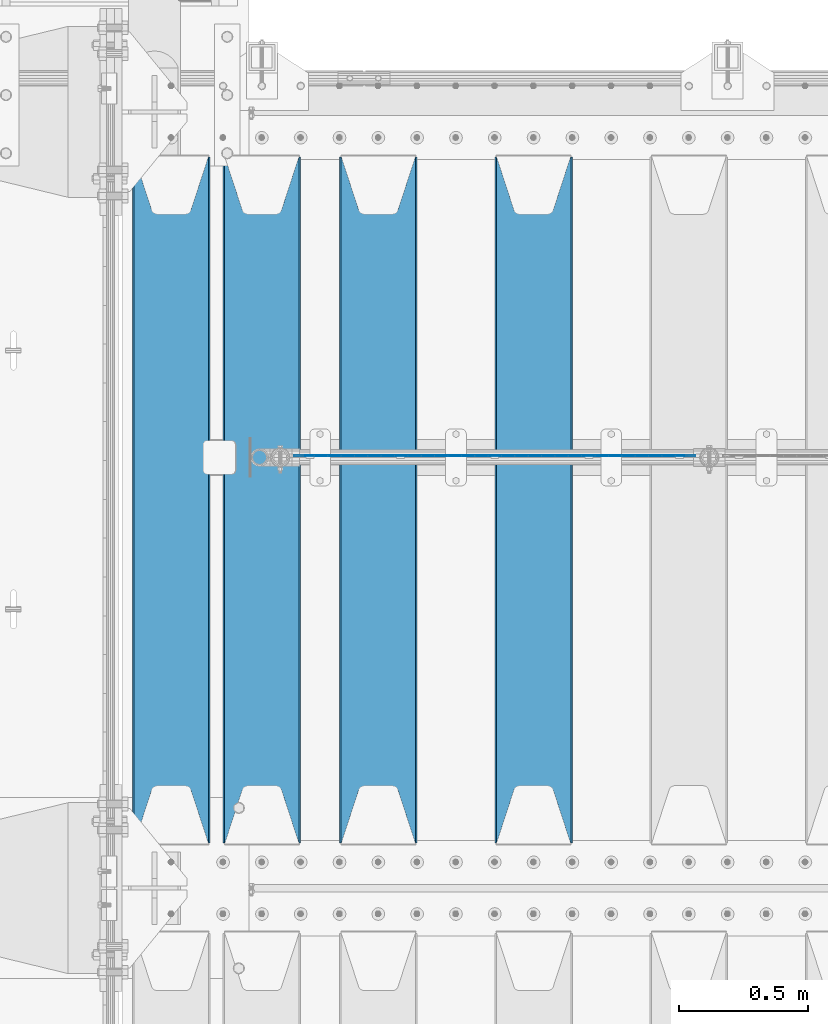
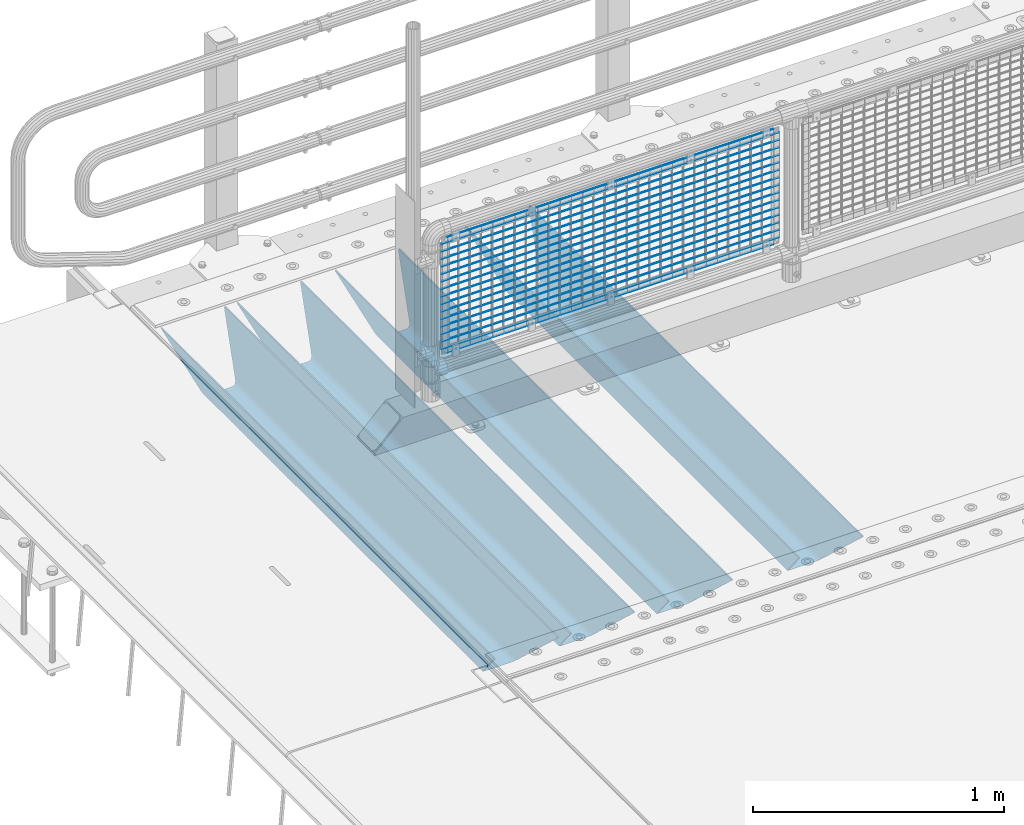
# One storey, part 88 of 193: 21 beams.
"""IFC2X3 building model written with IfcOpenShell, lengths in millimetres."""

from ifc_helpers import new_model, si_unit, frame, origin_with_axes, place, context, subcontext, project, spatial, faceted_brep, material, type_object, element, save


model = new_model("IFC2X3")

# Units and contexts
model_context = context("Model", 3, precision=1e-05, world=origin_with_axes())
body_context = subcontext(model_context, "Body", "Model", "MODEL_VIEW")
ifc_project = project(units=[si_unit("LENGTHUNIT", "METRE", prefix="MILLI"), si_unit("AREAUNIT", "SQUARE_METRE"), si_unit("VOLUMEUNIT", "CUBIC_METRE"), si_unit("MASSUNIT", "GRAM", prefix="KILO"), si_unit("TIMEUNIT", "SECOND"), si_unit("PLANEANGLEUNIT", "RADIAN"), si_unit("SOLIDANGLEUNIT", "STERADIAN"), si_unit("THERMODYNAMICTEMPERATUREUNIT", "DEGREE_CELSIUS"), si_unit("LUMINOUSINTENSITYUNIT", "LUMEN")], contexts=[model_context])

# Site, building, storey
site_placement = place(None, origin_with_axes())
site = spatial("IfcSite", under=ifc_project, at=site_placement, CompositionType="ELEMENT")
building_placement = place(site_placement, origin_with_axes())
building = spatial("IfcBuilding", under=site, at=building_placement, Name="Standard", CompositionType="ELEMENT")
storey_placement = place(building_placement, origin_with_axes())
storey = spatial("IfcBuildingStorey", under=building, at=storey_placement, Name="Undefined", CompositionType="ELEMENT", Elevation=0.0)

# Beams
ifc_material_1 = material(Name="STEEL/S355N")
beam_type_1 = type_object("IfcBeamType", PredefinedType="NOTDEFINED")
beam_1_placement = place(storey_placement, frame((-40850.0, 27175.0, -115.0), z_axis=(0.0, 0.0, 1.0), x_axis=(0.0, 1.0, 0.0)))
element("IfcBeam", 1, at=beam_1_placement, inside=storey, type_object=beam_type_1, material=ifc_material_1, context=body_context, shape_type="Brep", body=[
    faceted_brep([(0.0, 150.0, 115.0), (0.0, 143.689999999999, 115.0), (2650.00000000297, 143.689999999999, 115.0), (2650.00000000297, 150.0, 115.0), (2650.00000000297, 142.059565218398, 110.000000003094), (2650.00000000297, 148.3695652184, 110.000000003094), (2441.90079219209, -80.1103600731112, -98.0992078077845), (2437.7588105432, -77.5672621345584, -102.241189456673), (2434.06523489747, -74.4080125315522, -105.934765102404), (2430.9108609509, -70.710272125576, -109.089139048974), (2428.37322971128, -66.5649389910068, -111.626770288588), (2426.51472138055, -62.0739139532889, -113.485278619323), (2425.38102192092, -57.3475956567672, -114.618978078955), (2424.99999999988, -52.5021667386536, -115.0), (2424.99999999988, 52.5021667386536, -115.0), (2425.38102192092, 57.3475956567672, -114.618978078955), (2426.51472138055, 62.0739139532889, -113.485278619323), (2428.37322971128, 66.5649389910068, -111.626770288588), (2430.9108609509, 70.710272125576, -109.089139048974), (2434.06523489747, 74.4080125315522, -105.934765102404), (2437.7588105432, 77.5672621345584, -102.241189456673), (2441.90079219209, 80.1103600731112, -98.0992078077846), (2446.38936140512, 81.9747917625791, -93.6106385947584), (2448.2494850041, 76.2713538057251, -91.7505149957729), (2444.62967112263, 74.76777986261, -95.3703288772456), (2441.28936334127, 72.7168944282894, -98.710636658607), (2438.31067330439, 70.1691124903846, -101.689326695487), (2435.76682334748, 67.1870637758839, -104.233176652398), (2433.72034654134, 63.8440531834895, -106.279653458539), (2432.22154950042, 60.222258798236, -107.778450499454), (2431.30727574265, 56.4107117849089, -108.692724257221), (2430.99999999987, 52.5031078186876, -109.0), (2430.99999999987, -52.5031078186876, -109.0), (2431.30727574265, -56.4107117849089, -108.692724257221), (2432.22154950042, -60.222258798236, -107.778450499454), (2433.72034654134, -63.8440531834895, -106.279653458539), (2435.76682334748, -67.1870637758839, -104.233176652398), (2438.31067330439, -70.1691124903846, -101.689326695487), (2441.28936334127, -72.7168944282894, -98.7106366586071), (2444.62967112263, -74.76777986261, -95.3703288772457), (2448.2494850041, -76.2713538057251, -91.7505149957729), (2650.00000000297, -142.059565218398, 110.000000003094), (2650.00000000297, -148.3695652184, 110.000000003094), (2446.38936140512, -81.9747917625791, -93.6106385947584), (2650.00000000297, -143.689999999999, 115.0), (2650.00000000297, -150.0, 115.0), (0.0, -143.689999999999, 115.0), (0.0, -150.0, 115.0), (0.0, -148.369565218261, 110.000000002667), (203.610638597427, -81.9747917625791, -93.6106385947584), (208.099207810446, -80.1103600731112, -98.0992078077845), (212.241189459342, -77.5672621345584, -102.241189456673), (215.93476510507, -74.4080125315522, -105.934765102404), (219.089139051641, -70.710272125576, -109.089139048974), (221.626770291256, -66.5649389910068, -111.626770288588), (223.485278621989, -62.0739139532889, -113.485278619323), (224.618978081624, -57.3475956567672, -114.618978078955), (225.000000002663, -52.5021667386536, -115.0), (225.000000002663, 52.5021667386536, -115.0), (224.618978081624, 57.3475956567672, -114.618978078955), (223.485278621989, 62.0739139532889, -113.485278619323), (221.626770291256, 66.5649389910068, -111.626770288588), (219.089139051641, 70.710272125576, -109.089139048974), (215.93476510507, 74.4080125315522, -105.934765102404), (212.241189459342, 77.5672621345584, -102.241189456673), (208.099207810446, 80.1103600731112, -98.0992078077846), (203.610638597427, 81.9747917625791, -93.6106385947584), (0.0, 148.369565218261, 110.000000002667), (0.0, 142.05956521826, 110.000000002667), (201.750514998439, 76.2713538057251, -91.7505149957729), (205.370328879915, 74.76777986261, -95.3703288772456), (208.710636661275, 72.7168944282894, -98.710636658607), (211.689326698157, 70.1691124903846, -101.689326695487), (214.233176655063, 67.1870637758839, -104.233176652398), (216.279653461206, 63.8440531834895, -106.279653458539), (217.778450502123, 60.222258798236, -107.778450499454), (218.69272425989, 56.4107117849089, -108.692724257221), (219.00000000267, 52.5031078186876, -109.0), (219.00000000267, -52.5031078186876, -109.0), (218.69272425989, -56.4107117849089, -108.692724257221), (217.778450502123, -60.222258798236, -107.778450499454), (216.279653461206, -63.8440531834895, -106.279653458539), (214.233176655063, -67.1870637758839, -104.233176652398), (211.689326698157, -70.1691124903846, -101.689326695487), (208.710636661275, -72.7168944282894, -98.7106366586071), (205.370328879915, -74.76777986261, -95.3703288772457), (201.750514998439, -76.2713538057251, -91.7505149957729), (0.0, -142.05956521826, 110.000000002667)], [[[0, 1, 2, 3]], [[3, 2, 4, 5]], [[6, 7, 8, 9, 10, 11, 12, 13, 14, 15, 16, 17, 18, 19, 20, 21, 22, 5, 4, 23, 24, 25, 26, 27, 28, 29, 30, 31, 32, 33, 34, 35, 36, 37, 38, 39, 40, 41, 42, 43]], [[44, 45, 42, 41]], [[46, 47, 45, 44]], [[43, 42, 45, 47, 48, 49]], [[6, 43, 49, 50]], [[7, 6, 50, 51]], [[8, 7, 51, 52]], [[9, 8, 52, 53]], [[10, 9, 53, 54]], [[11, 10, 54, 55]], [[12, 11, 55, 56]], [[13, 12, 56, 57]], [[14, 13, 57, 58]], [[15, 14, 58, 59]], [[16, 15, 59, 60]], [[17, 16, 60, 61]], [[18, 17, 61, 62]], [[19, 18, 62, 63]], [[20, 19, 63, 64]], [[21, 20, 64, 65]], [[22, 21, 65, 66]], [[0, 3, 5, 22, 66, 67]], [[1, 0, 67, 68]], [[23, 4, 2, 1, 68, 69]], [[24, 23, 69, 70]], [[25, 24, 70, 71]], [[26, 25, 71, 72]], [[27, 26, 72, 73]], [[28, 27, 73, 74]], [[29, 28, 74, 75]], [[30, 29, 75, 76]], [[31, 30, 76, 77]], [[32, 31, 77, 78]], [[33, 32, 78, 79]], [[34, 33, 79, 80]], [[35, 34, 80, 81]], [[36, 35, 81, 82]], [[37, 36, 82, 83]], [[38, 37, 83, 84]], [[39, 38, 84, 85]], [[40, 39, 85, 86]], [[46, 44, 41, 40, 86, 87]], [[47, 46, 87, 48]], [[86, 85, 84, 83, 82, 81, 80, 79, 78, 77, 76, 75, 74, 73, 72, 71, 70, 69, 68, 67, 66, 65, 64, 63, 62, 61, 60, 59, 58, 57, 56, 55, 54, 53, 52, 51, 50, 49, 48, 87]]]),
])
beam_2_placement = place(storey_placement, frame((-41450.0, 27175.0, -115.0), z_axis=(0.0, 0.0, 1.0), x_axis=(0.0, 1.0, 0.0)))
element("IfcBeam", 2, at=beam_2_placement, inside=storey, type_object=beam_type_1, material=ifc_material_1, context=body_context, shape_type="Brep", body=[
    faceted_brep([(0.0, 150.0, 115.0), (0.0, 143.689999999999, 115.0), (2650.00000000297, 143.689999999999, 115.0), (2650.00000000297, 150.0, 115.0), (2650.00000000297, 142.059565218398, 110.000000003094), (2650.00000000297, 148.3695652184, 110.000000003094), (2441.90079219209, -80.1103600731112, -98.0992078077845), (2437.7588105432, -77.5672621345584, -102.241189456673), (2434.06523489747, -74.4080125315522, -105.934765102404), (2430.9108609509, -70.710272125576, -109.089139048974), (2428.37322971128, -66.5649389910068, -111.626770288588), (2426.51472138055, -62.0739139532889, -113.485278619323), (2425.38102192092, -57.3475956567672, -114.618978078955), (2424.99999999988, -52.5021667386536, -115.0), (2424.99999999988, 52.5021667386536, -115.0), (2425.38102192092, 57.3475956567672, -114.618978078955), (2426.51472138055, 62.0739139532889, -113.485278619323), (2428.37322971128, 66.5649389910068, -111.626770288588), (2430.9108609509, 70.710272125576, -109.089139048974), (2434.06523489747, 74.4080125315522, -105.934765102404), (2437.7588105432, 77.5672621345584, -102.241189456673), (2441.90079219209, 80.1103600731112, -98.0992078077846), (2446.38936140512, 81.9747917625791, -93.6106385947584), (2448.2494850041, 76.2713538057251, -91.7505149957729), (2444.62967112263, 74.76777986261, -95.3703288772456), (2441.28936334127, 72.7168944282894, -98.710636658607), (2438.31067330439, 70.1691124903846, -101.689326695487), (2435.76682334748, 67.1870637758839, -104.233176652398), (2433.72034654134, 63.8440531834895, -106.279653458539), (2432.22154950042, 60.222258798236, -107.778450499454), (2431.30727574265, 56.4107117849089, -108.692724257221), (2430.99999999987, 52.5031078186876, -109.0), (2430.99999999987, -52.5031078186876, -109.0), (2431.30727574265, -56.4107117849089, -108.692724257221), (2432.22154950042, -60.222258798236, -107.778450499454), (2433.72034654134, -63.8440531834895, -106.279653458539), (2435.76682334748, -67.1870637758839, -104.233176652398), (2438.31067330439, -70.1691124903846, -101.689326695487), (2441.28936334127, -72.7168944282894, -98.7106366586071), (2444.62967112263, -74.76777986261, -95.3703288772457), (2448.2494850041, -76.2713538057251, -91.7505149957729), (2650.00000000297, -142.059565218398, 110.000000003094), (2650.00000000297, -148.3695652184, 110.000000003094), (2446.38936140512, -81.9747917625791, -93.6106385947584), (2650.00000000297, -143.689999999999, 115.0), (2650.00000000297, -150.0, 115.0), (0.0, -143.689999999999, 115.0), (0.0, -150.0, 115.0), (0.0, -148.369565218261, 110.000000002667), (203.610638597427, -81.9747917625791, -93.6106385947584), (208.099207810446, -80.1103600731112, -98.0992078077845), (212.241189459342, -77.5672621345584, -102.241189456673), (215.93476510507, -74.4080125315522, -105.934765102404), (219.089139051641, -70.710272125576, -109.089139048974), (221.626770291256, -66.5649389910068, -111.626770288588), (223.485278621989, -62.0739139532889, -113.485278619323), (224.618978081624, -57.3475956567672, -114.618978078955), (225.000000002663, -52.5021667386536, -115.0), (225.000000002663, 52.5021667386536, -115.0), (224.618978081624, 57.3475956567672, -114.618978078955), (223.485278621989, 62.0739139532889, -113.485278619323), (221.626770291256, 66.5649389910068, -111.626770288588), (219.089139051641, 70.710272125576, -109.089139048974), (215.93476510507, 74.4080125315522, -105.934765102404), (212.241189459342, 77.5672621345584, -102.241189456673), (208.099207810446, 80.1103600731112, -98.0992078077846), (203.610638597427, 81.9747917625791, -93.6106385947584), (0.0, 148.369565218261, 110.000000002667), (0.0, 142.05956521826, 110.000000002667), (201.750514998439, 76.2713538057251, -91.7505149957729), (205.370328879915, 74.76777986261, -95.3703288772456), (208.710636661275, 72.7168944282894, -98.710636658607), (211.689326698157, 70.1691124903846, -101.689326695487), (214.233176655063, 67.1870637758839, -104.233176652398), (216.279653461206, 63.8440531834895, -106.279653458539), (217.778450502123, 60.222258798236, -107.778450499454), (218.69272425989, 56.4107117849089, -108.692724257221), (219.00000000267, 52.5031078186876, -109.0), (219.00000000267, -52.5031078186876, -109.0), (218.69272425989, -56.4107117849089, -108.692724257221), (217.778450502123, -60.222258798236, -107.778450499454), (216.279653461206, -63.8440531834895, -106.279653458539), (214.233176655063, -67.1870637758839, -104.233176652398), (211.689326698157, -70.1691124903846, -101.689326695487), (208.710636661275, -72.7168944282894, -98.7106366586071), (205.370328879915, -74.76777986261, -95.3703288772457), (201.750514998439, -76.2713538057251, -91.7505149957729), (0.0, -142.05956521826, 110.000000002667)], [[[0, 1, 2, 3]], [[3, 2, 4, 5]], [[6, 7, 8, 9, 10, 11, 12, 13, 14, 15, 16, 17, 18, 19, 20, 21, 22, 5, 4, 23, 24, 25, 26, 27, 28, 29, 30, 31, 32, 33, 34, 35, 36, 37, 38, 39, 40, 41, 42, 43]], [[44, 45, 42, 41]], [[46, 47, 45, 44]], [[43, 42, 45, 47, 48, 49]], [[6, 43, 49, 50]], [[7, 6, 50, 51]], [[8, 7, 51, 52]], [[9, 8, 52, 53]], [[10, 9, 53, 54]], [[11, 10, 54, 55]], [[12, 11, 55, 56]], [[13, 12, 56, 57]], [[14, 13, 57, 58]], [[15, 14, 58, 59]], [[16, 15, 59, 60]], [[17, 16, 60, 61]], [[18, 17, 61, 62]], [[19, 18, 62, 63]], [[20, 19, 63, 64]], [[21, 20, 64, 65]], [[22, 21, 65, 66]], [[0, 3, 5, 22, 66, 67]], [[1, 0, 67, 68]], [[23, 4, 2, 1, 68, 69]], [[24, 23, 69, 70]], [[25, 24, 70, 71]], [[26, 25, 71, 72]], [[27, 26, 72, 73]], [[28, 27, 73, 74]], [[29, 28, 74, 75]], [[30, 29, 75, 76]], [[31, 30, 76, 77]], [[32, 31, 77, 78]], [[33, 32, 78, 79]], [[34, 33, 79, 80]], [[35, 34, 80, 81]], [[36, 35, 81, 82]], [[37, 36, 82, 83]], [[38, 37, 83, 84]], [[39, 38, 84, 85]], [[40, 39, 85, 86]], [[46, 44, 41, 40, 86, 87]], [[47, 46, 87, 48]], [[86, 85, 84, 83, 82, 81, 80, 79, 78, 77, 76, 75, 74, 73, 72, 71, 70, 69, 68, 67, 66, 65, 64, 63, 62, 61, 60, 59, 58, 57, 56, 55, 54, 53, 52, 51, 50, 49, 48, 87]]]),
])
beam_3_placement = place(storey_placement, frame((-41900.0, 27175.0, -115.0), z_axis=(0.0, 0.0, 1.0), x_axis=(0.0, 1.0, 0.0)))
element("IfcBeam", 3, at=beam_3_placement, inside=storey, type_object=beam_type_1, material=ifc_material_1, context=body_context, shape_type="Brep", body=[
    faceted_brep([(0.0, 150.0, 115.0), (0.0, 143.689999999999, 115.0), (2650.00000000297, 143.689999999999, 115.0), (2650.00000000297, 150.0, 115.0), (2650.00000000297, 142.059565218398, 110.000000003094), (2650.00000000297, 148.3695652184, 110.000000003094), (2441.90079219209, -80.1103600731112, -98.0992078077845), (2437.7588105432, -77.5672621345584, -102.241189456673), (2434.06523489747, -74.4080125315522, -105.934765102404), (2430.9108609509, -70.710272125576, -109.089139048974), (2428.37322971128, -66.5649389910068, -111.626770288588), (2426.51472138055, -62.0739139532889, -113.485278619323), (2425.38102192092, -57.3475956567672, -114.618978078955), (2424.99999999988, -52.5021667386536, -115.0), (2424.99999999988, 52.5021667386536, -115.0), (2425.38102192092, 57.3475956567672, -114.618978078955), (2426.51472138055, 62.0739139532889, -113.485278619323), (2428.37322971128, 66.5649389910068, -111.626770288588), (2430.9108609509, 70.710272125576, -109.089139048974), (2434.06523489747, 74.4080125315522, -105.934765102404), (2437.7588105432, 77.5672621345584, -102.241189456673), (2441.90079219209, 80.1103600731112, -98.0992078077846), (2446.38936140512, 81.9747917625791, -93.6106385947584), (2448.2494850041, 76.2713538057251, -91.7505149957729), (2444.62967112263, 74.76777986261, -95.3703288772456), (2441.28936334127, 72.7168944282894, -98.710636658607), (2438.31067330439, 70.1691124903846, -101.689326695487), (2435.76682334748, 67.1870637758839, -104.233176652398), (2433.72034654134, 63.8440531834895, -106.279653458539), (2432.22154950042, 60.222258798236, -107.778450499454), (2431.30727574265, 56.4107117849089, -108.692724257221), (2430.99999999987, 52.5031078186876, -109.0), (2430.99999999987, -52.5031078186876, -109.0), (2431.30727574265, -56.4107117849089, -108.692724257221), (2432.22154950042, -60.222258798236, -107.778450499454), (2433.72034654134, -63.8440531834895, -106.279653458539), (2435.76682334748, -67.1870637758839, -104.233176652398), (2438.31067330439, -70.1691124903846, -101.689326695487), (2441.28936334127, -72.7168944282894, -98.7106366586071), (2444.62967112263, -74.76777986261, -95.3703288772457), (2448.2494850041, -76.2713538057251, -91.7505149957729), (2650.00000000297, -142.059565218398, 110.000000003094), (2650.00000000297, -148.3695652184, 110.000000003094), (2446.38936140512, -81.9747917625791, -93.6106385947584), (2650.00000000297, -143.689999999999, 115.0), (2650.00000000297, -150.0, 115.0), (0.0, -143.689999999999, 115.0), (0.0, -150.0, 115.0), (0.0, -148.369565218261, 110.000000002667), (203.610638597427, -81.9747917625791, -93.6106385947584), (208.099207810446, -80.1103600731112, -98.0992078077845), (212.241189459342, -77.5672621345584, -102.241189456673), (215.93476510507, -74.4080125315522, -105.934765102404), (219.089139051641, -70.710272125576, -109.089139048974), (221.626770291256, -66.5649389910068, -111.626770288588), (223.485278621989, -62.0739139532889, -113.485278619323), (224.618978081624, -57.3475956567672, -114.618978078955), (225.000000002663, -52.5021667386536, -115.0), (225.000000002663, 52.5021667386536, -115.0), (224.618978081624, 57.3475956567672, -114.618978078955), (223.485278621989, 62.0739139532889, -113.485278619323), (221.626770291256, 66.5649389910068, -111.626770288588), (219.089139051641, 70.710272125576, -109.089139048974), (215.93476510507, 74.4080125315522, -105.934765102404), (212.241189459342, 77.5672621345584, -102.241189456673), (208.099207810446, 80.1103600731112, -98.0992078077846), (203.610638597427, 81.9747917625791, -93.6106385947584), (0.0, 148.369565218261, 110.000000002667), (0.0, 142.05956521826, 110.000000002667), (201.750514998439, 76.2713538057251, -91.7505149957729), (205.370328879915, 74.76777986261, -95.3703288772456), (208.710636661275, 72.7168944282894, -98.710636658607), (211.689326698157, 70.1691124903846, -101.689326695487), (214.233176655063, 67.1870637758839, -104.233176652398), (216.279653461206, 63.8440531834895, -106.279653458539), (217.778450502123, 60.222258798236, -107.778450499454), (218.69272425989, 56.4107117849089, -108.692724257221), (219.00000000267, 52.5031078186876, -109.0), (219.00000000267, -52.5031078186876, -109.0), (218.69272425989, -56.4107117849089, -108.692724257221), (217.778450502123, -60.222258798236, -107.778450499454), (216.279653461206, -63.8440531834895, -106.279653458539), (214.233176655063, -67.1870637758839, -104.233176652398), (211.689326698157, -70.1691124903846, -101.689326695487), (208.710636661275, -72.7168944282894, -98.7106366586071), (205.370328879915, -74.76777986261, -95.3703288772457), (201.750514998439, -76.2713538057251, -91.7505149957729), (0.0, -142.05956521826, 110.000000002667)], [[[0, 1, 2, 3]], [[3, 2, 4, 5]], [[6, 7, 8, 9, 10, 11, 12, 13, 14, 15, 16, 17, 18, 19, 20, 21, 22, 5, 4, 23, 24, 25, 26, 27, 28, 29, 30, 31, 32, 33, 34, 35, 36, 37, 38, 39, 40, 41, 42, 43]], [[44, 45, 42, 41]], [[46, 47, 45, 44]], [[43, 42, 45, 47, 48, 49]], [[6, 43, 49, 50]], [[7, 6, 50, 51]], [[8, 7, 51, 52]], [[9, 8, 52, 53]], [[10, 9, 53, 54]], [[11, 10, 54, 55]], [[12, 11, 55, 56]], [[13, 12, 56, 57]], [[14, 13, 57, 58]], [[15, 14, 58, 59]], [[16, 15, 59, 60]], [[17, 16, 60, 61]], [[18, 17, 61, 62]], [[19, 18, 62, 63]], [[20, 19, 63, 64]], [[21, 20, 64, 65]], [[22, 21, 65, 66]], [[0, 3, 5, 22, 66, 67]], [[1, 0, 67, 68]], [[23, 4, 2, 1, 68, 69]], [[24, 23, 69, 70]], [[25, 24, 70, 71]], [[26, 25, 71, 72]], [[27, 26, 72, 73]], [[28, 27, 73, 74]], [[29, 28, 74, 75]], [[30, 29, 75, 76]], [[31, 30, 76, 77]], [[32, 31, 77, 78]], [[33, 32, 78, 79]], [[34, 33, 79, 80]], [[35, 34, 80, 81]], [[36, 35, 81, 82]], [[37, 36, 82, 83]], [[38, 37, 83, 84]], [[39, 38, 84, 85]], [[40, 39, 85, 86]], [[46, 44, 41, 40, 86, 87]], [[47, 46, 87, 48]], [[86, 85, 84, 83, 82, 81, 80, 79, 78, 77, 76, 75, 74, 73, 72, 71, 70, 69, 68, 67, 66, 65, 64, 63, 62, 61, 60, 59, 58, 57, 56, 55, 54, 53, 52, 51, 50, 49, 48, 87]]]),
])
beam_4_placement = place(storey_placement, frame((-42250.0, 27175.0, -115.0), z_axis=(0.0, 0.0, 1.0), x_axis=(0.0, 1.0, 0.0)))
element("IfcBeam", 4, at=beam_4_placement, inside=storey, type_object=beam_type_1, material=ifc_material_1, context=body_context, shape_type="Brep", body=[
    faceted_brep([(0.0, 150.0, 115.0), (0.0, 143.689999999999, 115.0), (2650.00000000297, 143.689999999999, 115.0), (2650.00000000297, 150.0, 115.0), (2650.00000000297, 142.059565218398, 110.000000003094), (2650.00000000297, 148.3695652184, 110.000000003094), (2441.90079219209, -80.1103600731112, -98.0992078077845), (2437.7588105432, -77.5672621345584, -102.241189456673), (2434.06523489747, -74.4080125315522, -105.934765102404), (2430.9108609509, -70.710272125576, -109.089139048974), (2428.37322971128, -66.5649389910068, -111.626770288588), (2426.51472138055, -62.0739139532889, -113.485278619323), (2425.38102192092, -57.3475956567672, -114.618978078955), (2424.99999999988, -52.5021667386536, -115.0), (2424.99999999988, 52.5021667386536, -115.0), (2425.38102192092, 57.3475956567672, -114.618978078955), (2426.51472138055, 62.0739139532889, -113.485278619323), (2428.37322971128, 66.5649389910068, -111.626770288588), (2430.9108609509, 70.710272125576, -109.089139048974), (2434.06523489747, 74.4080125315522, -105.934765102404), (2437.7588105432, 77.5672621345584, -102.241189456673), (2441.90079219209, 80.1103600731112, -98.0992078077846), (2446.38936140512, 81.9747917625791, -93.6106385947584), (2448.2494850041, 76.2713538057251, -91.7505149957729), (2444.62967112263, 74.76777986261, -95.3703288772456), (2441.28936334127, 72.7168944282894, -98.710636658607), (2438.31067330439, 70.1691124903846, -101.689326695487), (2435.76682334748, 67.1870637758839, -104.233176652398), (2433.72034654134, 63.8440531834895, -106.279653458539), (2432.22154950042, 60.222258798236, -107.778450499454), (2431.30727574265, 56.4107117849089, -108.692724257221), (2430.99999999987, 52.5031078186876, -109.0), (2430.99999999987, -52.5031078186876, -109.0), (2431.30727574265, -56.4107117849089, -108.692724257221), (2432.22154950042, -60.222258798236, -107.778450499454), (2433.72034654134, -63.8440531834895, -106.279653458539), (2435.76682334748, -67.1870637758839, -104.233176652398), (2438.31067330439, -70.1691124903846, -101.689326695487), (2441.28936334127, -72.7168944282894, -98.7106366586071), (2444.62967112263, -74.76777986261, -95.3703288772457), (2448.2494850041, -76.2713538057251, -91.7505149957729), (2650.00000000297, -142.059565218398, 110.000000003094), (2650.00000000297, -148.3695652184, 110.000000003094), (2446.38936140512, -81.9747917625791, -93.6106385947584), (2650.00000000297, -143.689999999999, 115.0), (2650.00000000297, -150.0, 115.0), (0.0, -143.689999999999, 115.0), (0.0, -150.0, 115.0), (0.0, -148.369565218261, 110.000000002667), (203.610638597427, -81.9747917625791, -93.6106385947584), (208.099207810446, -80.1103600731112, -98.0992078077845), (212.241189459342, -77.5672621345584, -102.241189456673), (215.93476510507, -74.4080125315522, -105.934765102404), (219.089139051641, -70.710272125576, -109.089139048974), (221.626770291256, -66.5649389910068, -111.626770288588), (223.485278621989, -62.0739139532889, -113.485278619323), (224.618978081624, -57.3475956567672, -114.618978078955), (225.000000002663, -52.5021667386536, -115.0), (225.000000002663, 52.5021667386536, -115.0), (224.618978081624, 57.3475956567672, -114.618978078955), (223.485278621989, 62.0739139532889, -113.485278619323), (221.626770291256, 66.5649389910068, -111.626770288588), (219.089139051641, 70.710272125576, -109.089139048974), (215.93476510507, 74.4080125315522, -105.934765102404), (212.241189459342, 77.5672621345584, -102.241189456673), (208.099207810446, 80.1103600731112, -98.0992078077846), (203.610638597427, 81.9747917625791, -93.6106385947584), (0.0, 148.369565218261, 110.000000002667), (0.0, 142.05956521826, 110.000000002667), (201.750514998439, 76.2713538057251, -91.7505149957729), (205.370328879915, 74.76777986261, -95.3703288772456), (208.710636661275, 72.7168944282894, -98.710636658607), (211.689326698157, 70.1691124903846, -101.689326695487), (214.233176655063, 67.1870637758839, -104.233176652398), (216.279653461206, 63.8440531834895, -106.279653458539), (217.778450502123, 60.222258798236, -107.778450499454), (218.69272425989, 56.4107117849089, -108.692724257221), (219.00000000267, 52.5031078186876, -109.0), (219.00000000267, -52.5031078186876, -109.0), (218.69272425989, -56.4107117849089, -108.692724257221), (217.778450502123, -60.222258798236, -107.778450499454), (216.279653461206, -63.8440531834895, -106.279653458539), (214.233176655063, -67.1870637758839, -104.233176652398), (211.689326698157, -70.1691124903846, -101.689326695487), (208.710636661275, -72.7168944282894, -98.7106366586071), (205.370328879915, -74.76777986261, -95.3703288772457), (201.750514998439, -76.2713538057251, -91.7505149957729), (0.0, -142.05956521826, 110.000000002667)], [[[0, 1, 2, 3]], [[3, 2, 4, 5]], [[6, 7, 8, 9, 10, 11, 12, 13, 14, 15, 16, 17, 18, 19, 20, 21, 22, 5, 4, 23, 24, 25, 26, 27, 28, 29, 30, 31, 32, 33, 34, 35, 36, 37, 38, 39, 40, 41, 42, 43]], [[44, 45, 42, 41]], [[46, 47, 45, 44]], [[43, 42, 45, 47, 48, 49]], [[6, 43, 49, 50]], [[7, 6, 50, 51]], [[8, 7, 51, 52]], [[9, 8, 52, 53]], [[10, 9, 53, 54]], [[11, 10, 54, 55]], [[12, 11, 55, 56]], [[13, 12, 56, 57]], [[14, 13, 57, 58]], [[15, 14, 58, 59]], [[16, 15, 59, 60]], [[17, 16, 60, 61]], [[18, 17, 61, 62]], [[19, 18, 62, 63]], [[20, 19, 63, 64]], [[21, 20, 64, 65]], [[22, 21, 65, 66]], [[0, 3, 5, 22, 66, 67]], [[1, 0, 67, 68]], [[23, 4, 2, 1, 68, 69]], [[24, 23, 69, 70]], [[25, 24, 70, 71]], [[26, 25, 71, 72]], [[27, 26, 72, 73]], [[28, 27, 73, 74]], [[29, 28, 74, 75]], [[30, 29, 75, 76]], [[31, 30, 76, 77]], [[32, 31, 77, 78]], [[33, 32, 78, 79]], [[34, 33, 79, 80]], [[35, 34, 80, 81]], [[36, 35, 81, 82]], [[37, 36, 82, 83]], [[38, 37, 83, 84]], [[39, 38, 84, 85]], [[40, 39, 85, 86]], [[46, 44, 41, 40, 86, 87]], [[47, 46, 87, 48]], [[86, 85, 84, 83, 82, 81, 80, 79, 78, 77, 76, 75, 74, 73, 72, 71, 70, 69, 68, 67, 66, 65, 64, 63, 62, 61, 60, 59, 58, 57, 56, 55, 54, 53, 52, 51, 50, 49, 48, 87]]]),
])
ifc_material_2 = material(Name="Misc_Undefined")
beam_type_2 = type_object("IfcBeamType", Name="D3", PredefinedType="NOTDEFINED")
for number, where, z_axis, x_axis in (
    (5, (-41774.0, 28670.5, 851.596999999999), (0.0, 0.0, 1.0), (1.0, 0.0, 0.0)),
    (6, (-41774.0, 28670.5, 669.452), (0.0, 0.0, 1.0), (1.0, 0.0, 0.0)),
    (7, (-41774.0, 28670.5, 523.736), (0.0, 0.0, 1.0), (1.0, 0.0, 0.0)),
    (8, (-41774.0, 28670.5, 487.307), (0.0, 0.0, 1.0), (1.0, 0.0, 0.0)),
    (9, (-41774.0, 28670.5, 705.881), (0.0, 0.0, 1.0), (1.0, 0.0, 0.0)),
    (10, (-41774.0, 28670.5, 596.594), (0.0, 0.0, 1.0), (1.0, 0.0, 0.0)),
    (11, (-41774.0, 28670.5, 450.878), (0.0, 0.0, 1.0), (1.0, 0.0, 0.0)),
    (12, (-41774.0, 28670.5, 815.167999999999), (0.0, 0.0, 1.0), (1.0, 0.0, 0.0)),
    (13, (-41774.0, 28670.5, 888.025999999999), (0.0, 0.0, 1.0), (1.0, 0.0, 0.0)),
    (14, (-41774.0, 28670.5, 778.738999999999), (0.0, 0.0, 1.0), (1.0, 0.0, 0.0)),
    (15, (-41774.0, 28670.5, 742.309999999999), (0.0, 0.0, 1.0), (1.0, 0.0, 0.0)),
    (16, (-41774.0, 28670.5, 633.023), (0.0, 0.0, 1.0), (1.0, 0.0, 0.0)),
    (17, (-41774.0, 28670.5, 560.165), (0.0, 0.0, 1.0), (1.0, 0.0, 0.0)),
    (18, (-41774.0, 28670.5, 414.449), (0.0, 0.0, 1.0), (1.0, 0.0, 0.0)),
):
    element("IfcBeam", number, at=place(storey_placement, frame(where, z_axis=z_axis, x_axis=x_axis)), inside=storey, type_object=beam_type_2, material=ifc_material_2, ObjectType="D3", context=body_context, shape_type="Brep", body=[
        faceted_brep([(0.0, -1.49999999999636, 3.63797880709171e-12), (0.0, -0.75, -1.29903810567669), (1548.0, -0.75, -1.29903810567669), (1548.0, -1.5, 0.0), (0.0, 0.75, -1.29903810567669), (1548.0, 0.75, -1.29903810567669), (0.0, 1.50000000000364, 7.27595761418343e-12), (1548.0, 1.5, 0.0), (0.0, 0.75, 1.29903810567669), (1548.0, 0.75, 1.29903810567669), (0.0, -0.75, 1.29903810567669), (1548.0, -0.75, 1.29903810567669)], [[[0, 1, 2, 3]], [[1, 4, 5, 2]], [[4, 6, 7, 5]], [[6, 8, 9, 7]], [[8, 10, 11, 9]], [[10, 0, 3, 11]], [[5, 7, 9, 11, 3, 2]], [[10, 8, 6, 4, 1, 0]]]),
    ])
beam_5_placement = place(storey_placement, frame((-41749.0, 28670.5, 353.02), z_axis=(0.0, 0.0, 1.0), x_axis=(1.0, 0.0, 0.0)))
element("IfcBeam", 19, at=beam_5_placement, inside=storey, type_object=beam_type_2, material=ifc_material_2, ObjectType="D3", context=body_context, shape_type="Brep", body=[
    faceted_brep([(0.0, -1.49999999999636, 3.63797880709171e-12), (0.0, -0.75, -1.29903810567669), (1498.0, -0.75, -1.29903810567669), (1498.0, -1.5, 0.0), (0.0, 0.75, -1.29903810567669), (1498.0, 0.75, -1.29903810567663), (0.0, 1.50000000000364, 7.27595761418343e-12), (1498.0, 1.5, 0.0), (0.0, 0.75, 1.29903810567669), (1498.0, 0.75, 1.29903810567669), (0.0, -0.75, 1.29903810567669), (1498.0, -0.75, 1.29903810567669)], [[[0, 1, 2, 3]], [[1, 4, 5, 2]], [[4, 6, 7, 5]], [[6, 8, 9, 7]], [[8, 10, 11, 9]], [[10, 0, 3, 11]], [[5, 7, 9, 11, 3, 2]], [[10, 8, 6, 4, 1, 0]]]),
])
beam_6_placement = place(storey_placement, frame((-41774.0, 28670.5, 378.02), z_axis=(0.0, 0.0, 1.0), x_axis=(1.0, 0.0, 0.0)))
element("IfcBeam", 20, at=beam_6_placement, inside=storey, type_object=beam_type_2, material=ifc_material_2, ObjectType="D3", context=body_context, shape_type="Brep", body=[
    faceted_brep([(0.0, -1.49999999999636, 3.63797880709171e-12), (0.0, -0.75, -1.29903810567669), (1548.0, -0.75, -1.29903810567669), (1548.0, -1.5, 0.0), (0.0, 0.75, -1.29903810567669), (1548.0, 0.75, -1.29903810567669), (0.0, 1.50000000000364, 7.27595761418343e-12), (1548.0, 1.5, 0.0), (0.0, 0.75, 1.29903810567669), (1548.0, 0.75, 1.29903810567669), (0.0, -0.75, 1.29903810567669), (1548.0, -0.75, 1.29903810567669)], [[[0, 1, 2, 3]], [[1, 4, 5, 2]], [[4, 6, 7, 5]], [[6, 8, 9, 7]], [[8, 10, 11, 9]], [[10, 0, 3, 11]], [[5, 7, 9, 11, 3, 2]], [[10, 8, 6, 4, 1, 0]]]),
])
beam_7_placement = place(storey_placement, frame((-41749.0, 28670.5, 913.02), z_axis=(0.0, 0.0, 1.0), x_axis=(1.0, 0.0, 0.0)))
element("IfcBeam", 21, at=beam_7_placement, inside=storey, type_object=beam_type_2, material=ifc_material_2, ObjectType="D3", context=body_context, shape_type="Brep", body=[
    faceted_brep([(0.0, -1.49999999999636, 3.63797880709171e-12), (0.0, -0.75, -1.29903810567669), (1498.0, -0.75, -1.29903810567669), (1498.0, -1.5, 0.0), (0.0, 0.75, -1.29903810567669), (1498.0, 0.75, -1.29903810567663), (0.0, 1.50000000000364, 7.27595761418343e-12), (1498.0, 1.5, 0.0), (0.0, 0.75, 1.29903810567669), (1498.0, 0.75, 1.29903810567669), (0.0, -0.75, 1.29903810567669), (1498.0, -0.75, 1.29903810567669)], [[[0, 1, 2, 3]], [[1, 4, 5, 2]], [[4, 6, 7, 5]], [[6, 8, 9, 7]], [[8, 10, 11, 9]], [[10, 0, 3, 11]], [[5, 7, 9, 11, 3, 2]], [[10, 8, 6, 4, 1, 0]]]),
])

save(model, "model.ifc")
